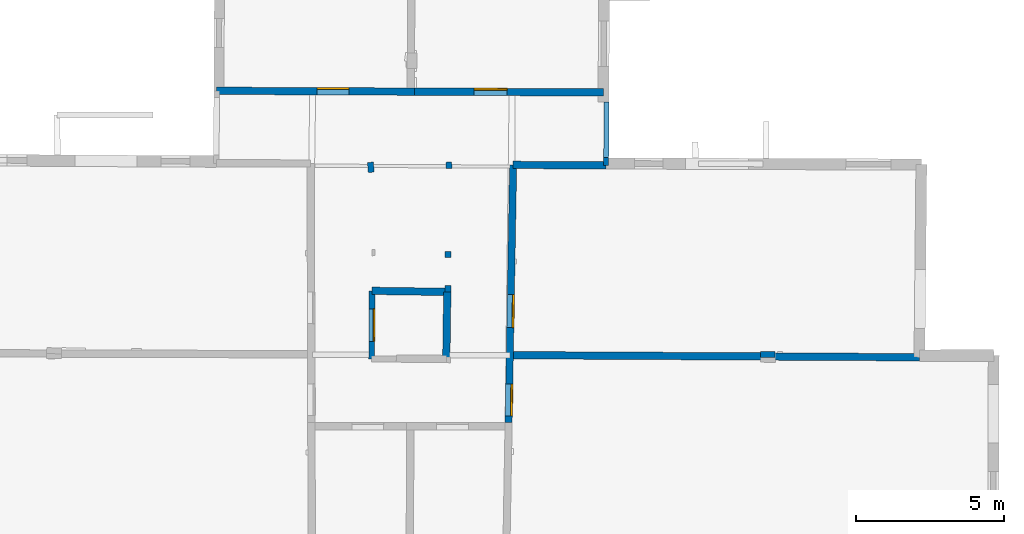
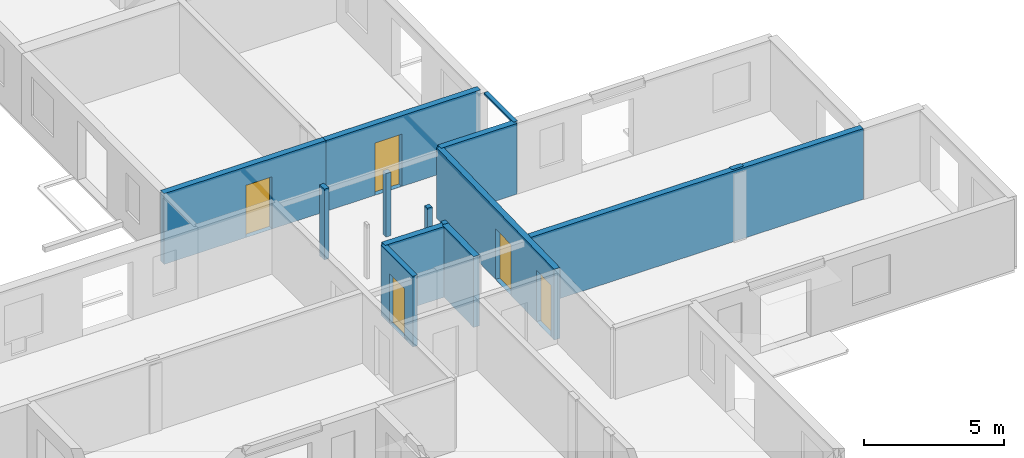
# One storey, part 6 of 17: 14 walls, 5 doors, 6 openings.
"""IFC2X3 building model written with IfcOpenShell, lengths in metres."""

from ifc_helpers import new_model, entity, si_unit, converted_unit, derived_unit, direction, frame, frame_2d, origin, origin_2d_with_axis, place, context, subcontext, project, spatial, polyline, rectangle, outline, extrude, clip, halfspace, source, transform, mapped, material, layer, layer_set, layer_usage, type_object, type_shapes, element, fill, save


model = new_model("IFC2X3")

# Units and contexts
model_context = context("Model", 3, precision=1e-05, world=origin(), true_north=direction((0.0, 1.0)))
body_context = subcontext(model_context, "Body", "Model", "MODEL_VIEW")
ifc_project = project(units=[si_unit("LENGTHUNIT", "METRE"), si_unit("AREAUNIT", "SQUARE_METRE"), si_unit("VOLUMEUNIT", "CUBIC_METRE"), converted_unit("PLANEANGLEUNIT", "DEGREE", entity("IfcRatioMeasure", 0.0174532925199433), si_unit("PLANEANGLEUNIT", "RADIAN"), dimensions=[0, 0, 0, 0, 0, 0, 0]), si_unit("MASSUNIT", "GRAM", prefix="KILO"), derived_unit("MASSDENSITYUNIT", [(si_unit("MASSUNIT", "GRAM", prefix="KILO"), 1), (si_unit("LENGTHUNIT", "METRE"), -3)]), derived_unit("MOMENTOFINERTIAUNIT", [(si_unit("LENGTHUNIT", "METRE"), 4)]), si_unit("TIMEUNIT", "SECOND"), si_unit("FREQUENCYUNIT", "HERTZ"), si_unit("THERMODYNAMICTEMPERATUREUNIT", "DEGREE_CELSIUS"), derived_unit("THERMALTRANSMITTANCEUNIT", [(si_unit("MASSUNIT", "GRAM", prefix="KILO"), 1), (si_unit("THERMODYNAMICTEMPERATUREUNIT", "KELVIN"), -1), (si_unit("TIMEUNIT", "SECOND"), -3)]), derived_unit("VOLUMETRICFLOWRATEUNIT", [(si_unit("LENGTHUNIT", "METRE"), 3), (si_unit("TIMEUNIT", "SECOND"), -1)]), si_unit("ELECTRICCURRENTUNIT", "AMPERE"), si_unit("ELECTRICVOLTAGEUNIT", "VOLT"), si_unit("POWERUNIT", "WATT"), si_unit("FORCEUNIT", "NEWTON", prefix="KILO"), si_unit("ILLUMINANCEUNIT", "LUX"), si_unit("LUMINOUSFLUXUNIT", "LUMEN"), si_unit("LUMINOUSINTENSITYUNIT", "CANDELA"), derived_unit("USERDEFINED", [(si_unit("MASSUNIT", "GRAM", prefix="KILO"), -1), (si_unit("LENGTHUNIT", "METRE"), -2), (si_unit("TIMEUNIT", "SECOND"), 3), (si_unit("LUMINOUSFLUXUNIT", "LUMEN"), 1)]), derived_unit("LINEARVELOCITYUNIT", [(si_unit("LENGTHUNIT", "METRE"), 1), (si_unit("TIMEUNIT", "SECOND"), -1)]), si_unit("PRESSUREUNIT", "PASCAL"), derived_unit("USERDEFINED", [(si_unit("LENGTHUNIT", "METRE"), -2), (si_unit("MASSUNIT", "GRAM", prefix="KILO"), 1), (si_unit("TIMEUNIT", "SECOND"), -2)]), derived_unit("LINEARFORCEUNIT", [(si_unit("MASSUNIT", "GRAM", prefix="KILO"), 1), (si_unit("LENGTHUNIT", "METRE"), 1), (si_unit("TIMEUNIT", "SECOND"), -2), (si_unit("LENGTHUNIT", "METRE"), -1)]), derived_unit("PLANARFORCEUNIT", [(si_unit("MASSUNIT", "GRAM", prefix="KILO"), 1), (si_unit("LENGTHUNIT", "METRE"), 1), (si_unit("TIMEUNIT", "SECOND"), -2), (si_unit("LENGTHUNIT", "METRE"), -2)])], contexts=[model_context])

# Site, building, storey
placement = place(None, origin())
site = spatial("IfcSite", under=ifc_project, at=placement, CompositionType="ELEMENT")
building = spatial("IfcBuilding", under=site, at=placement, CompositionType="ELEMENT")
storey_placement = place(placement, frame((0.0, 0.0, 12.0782108306885)))
storey = spatial("IfcBuildingStorey", under=building, at=storey_placement, Name="Level 5", CompositionType="ELEMENT", Elevation=12.0782108306885)

# Walls
ifc_material_1 = material(Name="Default wall")
ifc_layer_1 = layer(ifc_material_1, 0.25)
ifc_layer_set_1 = layer_set([ifc_layer_1], Name="wall_thickness_0.2500")
ifc_layer_usage_1 = layer_usage(ifc_layer_set_1, "AXIS2", "POSITIVE", -0.125)
wall_type_1 = type_object("IfcWallType", Name="wall_thickness_0.2500", PredefinedType="STANDARD", material=ifc_layer_set_1)
wall_1_placement = place(storey_placement, frame((7.44140047618452, 21.5416471038313, 0.0), z_axis=(0.0, 0.0, 1.0), x_axis=(-0.0141130984872263, -0.999900405265989, 0.0)))
element("IfcWallStandardCase", 1, at=wall_1_placement, inside=storey, type_object=wall_type_1, material=ifc_layer_usage_1, Name="Wall:255", ObjectType="Wall", context=body_context, shape_type="Clipping", body=[
    clip(clip(extrude(outline(polyline([(2.28926188819934, -0.125), (2.28926188819934, 0.125), (0.0, 0.125), (0.0, -0.125), (2.28926188819934, -0.125)])), origin(), (0.0, 0.0, 1.0), 3.09134044647217), halfspace(frame((2.06553112983233, 16.9692089835164, 9.08176747891542), z_axis=(-0.389130197139845, -0.00215358225991096, 0.921180249330909), x_axis=(0.00430704897289366, -0.999990590220069, -0.000518459702406835)), False)), halfspace(frame((-55.765283667153, 4.58856008528925, 6.35864093399329), z_axis=(-0.00360749198056489, 0.390483459134606, 0.920602875372374), x_axis=(0.679840338462808, -0.674176343923491, 0.288623234499112)), False)),
])
wall_2_placement = place(storey_placement, frame((9.66529580655071, 25.8279105453646, 0.0), z_axis=(0.0, 0.0, 1.0), x_axis=(0.999991390371742, -0.0041496002686868, 0.0)))
element("IfcWallStandardCase", 2, at=wall_2_placement, inside=storey, type_object=wall_type_1, material=ifc_layer_usage_1, Name="Wall:282", ObjectType="Wall", context=body_context, shape_type="Clipping", body=[
    clip(clip(extrude(outline(polyline([(3.13938459576782, -0.125), (3.13938459576782, 0.125), (0.0, 0.125), (0.0, -0.125), (3.13938459576782, -0.125)])), origin(), (0.0, 0.0, 1.0), 3.09134044647217), halfspace(frame((14.7416962136705, -6.52996104694493, 9.08176747891542), z_axis=(0.00172373620587876, 0.389132338640901, 0.921180249330909), x_axis=(-0.999983865431084, 0.00565686105937413, -0.000518459702406835)), False)), halfspace(frame((2.93787598171602, 51.4213412262231, 6.35864093399329), z_axis=(0.390500019911143, -0.000283382275309442, 0.920602875372374), x_axis=(-0.680916664311075, -0.673089239826897, 0.288623234499112)), False)),
])
wall_3_placement = place(storey_placement, frame((4.89979152095251, 21.5786000741626, 0.0), z_axis=(0.0, 0.0, 1.0), x_axis=(0.999894344321697, -0.0145361684595151, 0.0)))
element("IfcWallStandardCase", 3, at=wall_3_placement, inside=storey, type_object=wall_type_1, material=ifc_layer_usage_1, Name="Wall:289", ObjectType="Wall", context=body_context, shape_type="Clipping", body=[
    clip(clip(extrude(outline(polyline([(2.54187737420294, -0.125), (2.54187737420294, 0.125), (0.0, 0.125), (0.0, -0.125), (2.54187737420294, -0.125)])), origin(), (0.0, 0.0, 1.0), 3.09134044647217), halfspace(frame((19.5119589928247, -2.05835485575856, 9.08176747891542), z_axis=(-0.00231822825834028, 0.389129251098381, 0.921180249330909), x_axis=(-0.999988678338414, -0.00473015798140642, -0.000518459702406836)), False)), halfspace(frame((-6.95074935791861, 54.1698894244232, 5.79573318480268), z_axis=(-0.389877573655058, -0.00425334585105643, 0.920856876289642), x_axis=(0.920822647172364, 0.00783906332480271, 0.389902810378011)), False)),
])

# Wall, opening, door
wall_4_placement = place(storey_placement, frame((-0.341203083440317, 28.3289498440354, 0.0), z_axis=(0.0, 0.0, 1.0), x_axis=(0.999991697178327, -0.00407499379250348, 0.0)))
wall_4 = element("IfcWallStandardCase", 4, at=wall_4_placement, inside=storey, type_object=wall_type_1, material=ifc_layer_usage_1, Name="Wall:322", ObjectType="Wall", context=body_context, shape_type="Clipping", body=[
    clip(extrude(outline(polyline([(6.67924084701808, -0.125), (6.67924084701808, 0.125), (0.0, 0.125), (0.0, -0.125), (6.67924084701808, -0.125)])), origin(), (0.0, 0.0, 1.0), 3.09134044647217), halfspace(frame((-1.11521281073508, 47.5107035493444, 5.79573318480268), z_axis=(-0.389900734764027, -0.000174414893670282, 0.920856876289642), x_axis=(0.920854265394048, -0.00179453752182769, 0.389902810378011)), False)),
])
opening_1_placement = place(wall_4_placement, frame((3.3872048531384, -0.125, 0.00578975677490234)))
opening_1 = element("IfcOpeningElement", 5, at=opening_1_placement, cuts=wall_4, Name="Opening : 1075 x 2280 : 266", ObjectType="Opening", context=body_context, shape_type="SweptSolid", body=[
    extrude(rectangle(XDim=1.075, YDim=2.28, at=frame_2d((1.14, 0.5375), x_axis=(0.0, 1.0))), frame((0.0, 0.0, 0.0), z_axis=(0.0, 1.0, 0.0), x_axis=(0.0, 0.0, 1.0)), (0.0, 0.0, 1.0), 0.25),
])
ifc_material_2 = material(Name="Door Panel")
door_style_1 = type_object("IfcDoorStyle", Name="Door : 1075 x 2280mm", ConstructionType="NOTDEFINED", OperationType="SINGLE_SWING_RIGHT", ParameterTakesPrecedence=False, Sizeable=False, material=ifc_material_2)
shared_shape_1 = source(origin(), body_context, "Body", "SweptSolid", [
    extrude(rectangle(XDim=0.0625, YDim=1.075, at=origin_2d_with_axis()), frame((0.5375, 0.21875, 0.0), z_axis=(0.0, 0.0, 1.0), x_axis=(0.0, 1.0, 0.0)), (0.0, 0.0, 1.0), 2.28),
])
type_shapes(door_style_1, [shared_shape_1])
door_1_placement = place(opening_1_placement, origin())
door_1 = element("IfcDoor", 6, at=door_1_placement, inside=storey, type_object=door_style_1, Name="Door : 1075 x 2280mm : 50", ObjectType="Door : 1075 x 2280mm", OverallHeight=2.28, OverallWidth=1.075, context=body_context, shape_type="MappedRepresentation", body=[
    mapped(shared_shape_1, transform((0.0, 0.0, 0.0), scale=1.0)),
])
fill(opening_1, door_1)

wall_5_placement = place(storey_placement, frame((6.3379823070321, 28.3017319790451, 0.0), z_axis=(0.0, 0.0, 1.0), x_axis=(0.999991697084949, -0.00407501670713121, 0.0)))
wall_5 = element("IfcWallStandardCase", 7, at=wall_5_placement, inside=storey, type_object=wall_type_1, material=ifc_layer_usage_1, Name="Wall:323", ObjectType="Wall", context=body_context, shape_type="Clipping", body=[
    clip(extrude(outline(polyline([(6.37870934921096, -0.125), (6.37870934921096, 0.125), (0.0, 0.125), (0.0, -0.125), (6.37870934921096, -0.125)])), origin(), (0.0, 0.0, 1.0), 3.09134044647217), halfspace(frame((6.27907792952954, 48.9608799284421, 6.35864093399329), z_axis=(0.390499997689168, -0.000312507403043239, 0.920602875372374), x_axis=(-0.680966864234374, -0.673038452335433, 0.288623234499112)), False)),
])
opening_2_placement = place(wall_5_placement, frame((2.0109763124588, -0.125, 0.00578975677490234)))
opening_2 = element("IfcOpeningElement", 8, at=opening_2_placement, cuts=wall_5, Name="Opening : 1115 x 2280 : 267", ObjectType="Opening", context=body_context, shape_type="SweptSolid", body=[
    extrude(rectangle(XDim=1.115, YDim=2.28, at=frame_2d((1.14, 0.5575), x_axis=(0.0, 1.0))), frame((0.0, 0.0, 0.0), z_axis=(0.0, 1.0, 0.0), x_axis=(0.0, 0.0, 1.0)), (0.0, 0.0, 1.0), 0.25),
])
door_style_2 = type_object("IfcDoorStyle", Name="Door : 1115 x 2280mm", ConstructionType="NOTDEFINED", OperationType="SINGLE_SWING_RIGHT", ParameterTakesPrecedence=False, Sizeable=False, material=ifc_material_2)
shared_shape_2 = source(origin(), body_context, "Body", "SweptSolid", [
    extrude(rectangle(XDim=0.0625, YDim=1.115, at=origin_2d_with_axis()), frame((0.5575, 0.21875, 0.0), z_axis=(0.0, 0.0, 1.0), x_axis=(0.0, 1.0, 0.0)), (0.0, 0.0, 1.0), 2.28),
])
type_shapes(door_style_2, [shared_shape_2])
door_2_placement = place(opening_2_placement, origin())
door_2 = element("IfcDoor", 9, at=door_2_placement, inside=storey, type_object=door_style_2, Name="Door : 1115 x 2280mm : 51", ObjectType="Door : 1115 x 2280mm", OverallHeight=2.28, OverallWidth=1.115, context=body_context, shape_type="MappedRepresentation", body=[
    mapped(shared_shape_2, transform((0.0, 0.0, 0.0), scale=1.0)),
])
fill(opening_2, door_2)

# Wall
wall_6_placement = place(storey_placement, frame((9.61450464191011, 19.407159536809, 0.0), z_axis=(0.0, 0.0, 1.0), x_axis=(0.999986890430115, -0.00512044606555081, 0.0)))
element("IfcWallStandardCase", 10, at=wall_6_placement, inside=storey, type_object=wall_type_1, material=ifc_layer_usage_1, Name="Wall:357", ObjectType="Wall", context=body_context, shape_type="Clipping", body=[
    clip(extrude(outline(polyline([(13.763003531915, -0.125), (13.763003531915, 0.125), (0.0, 0.125), (0.0, -0.125), (13.763003531915, -0.125)])), origin(), (0.0, 0.0, 1.0), 3.09134044647217), halfspace(frame((14.7659423083296, -0.094718994949792, 9.08176747891542), z_axis=(0.00134594388447911, 0.38913382875009, 0.921180249330909), x_axis=(-0.999988886155912, 0.00468601794654678, -0.000518459702406836)), False)),
])

# Wall, opening, door
ifc_layer_2 = layer(ifc_material_1, 0.2)
ifc_layer_set_2 = layer_set([ifc_layer_2], Name="wall_thickness_0.2000")
ifc_layer_usage_2 = layer_usage(ifc_layer_set_2, "AXIS2", "POSITIVE", -0.1)
wall_type_2 = type_object("IfcWallType", Name="wall_thickness_0.2000", PredefinedType="STANDARD", material=ifc_layer_set_2)
wall_7_placement = place(storey_placement, frame((4.89979212972418, 21.5785997161123, 0.0), z_axis=(0.0, 0.0, 1.0), x_axis=(-0.00356916132915824, -0.999993630523418, 0.0)))
wall_7 = element("IfcWallStandardCase", 11, at=wall_7_placement, inside=storey, type_object=wall_type_2, material=ifc_layer_usage_2, Name="Wall:266", ObjectType="Wall", context=body_context, shape_type="Clipping", body=[
    clip(clip(extrude(outline(polyline([(2.29443294929788, -0.1), (2.29443294929788, 0.1), (0.0, 0.1), (0.0, -0.1), (2.29443294929788, -0.1)])), origin(), (0.0, 0.0, 1.0), 3.09134044647217), halfspace(frame((2.27222405000463, 19.4882103057675, 9.08176747891542), z_axis=(-0.389131272557736, 0.00194960515011499, 0.921180249330909), x_axis=(-0.00623729397913293, -0.999980413489862, -0.000518459702406836)), False)), halfspace(frame((-54.2428627602878, -6.35623495648199, 5.79573318480268), z_axis=(-2.2811012031869e-05, -0.389900773107391, 0.920856876289642), x_axis=(0.0022603386610801, 0.92085323984252, 0.389902810378011)), False)),
])
opening_3_placement = place(wall_7_placement, frame((0.61249935258112, -0.1, 0.00578975677490234)))
opening_3 = element("IfcOpeningElement", 12, at=opening_3_placement, cuts=wall_7, Name="Opening : 1095 x 2185 : 233", ObjectType="Opening", context=body_context, shape_type="SweptSolid", body=[
    extrude(rectangle(XDim=1.095, YDim=2.185, at=frame_2d((1.0925, 0.5475), x_axis=(0.0, 1.0))), frame((0.0, 0.0, 0.0), z_axis=(0.0, 1.0, 0.0), x_axis=(0.0, 0.0, 1.0)), (0.0, 0.0, 1.0), 0.2),
])
door_style_3 = type_object("IfcDoorStyle", Name="Door : 1095 x 2185mm", ConstructionType="NOTDEFINED", OperationType="SINGLE_SWING_RIGHT", ParameterTakesPrecedence=False, Sizeable=False, material=ifc_material_2)
shared_shape_3 = source(origin(), body_context, "Body", "SweptSolid", [
    extrude(rectangle(XDim=0.05, YDim=1.095, at=origin_2d_with_axis()), frame((0.5475, 0.175, 0.0), z_axis=(0.0, 0.0, 1.0), x_axis=(0.0, 1.0, 0.0)), (0.0, 0.0, 1.0), 2.185),
])
type_shapes(door_style_3, [shared_shape_3])
door_3_placement = place(opening_3_placement, origin())
door_3 = element("IfcDoor", 13, at=door_3_placement, inside=storey, type_object=door_style_3, Name="Door : 1095 x 2185mm : 40", ObjectType="Door : 1095 x 2185mm", OverallHeight=2.185, OverallWidth=1.095, context=body_context, shape_type="MappedRepresentation", body=[
    mapped(shared_shape_3, transform((0.0, 0.0, 0.0), scale=1.0)),
])
fill(opening_3, door_3)

# Walls
wall_8_placement = place(storey_placement, frame((18.0131439674887, 19.433039885868, 0.0), z_axis=(0.0, 0.0, 1.0), x_axis=(0.999992071495459, -0.00398207812852465, 0.0)))
element("IfcWallStandardCase", 14, at=wall_8_placement, inside=storey, type_object=wall_type_2, material=ifc_layer_usage_2, Name="Wall:305", ObjectType="Wall", context=body_context, shape_type="Clipping", body=[
    clip(extrude(outline(polyline([(0.489999841386866, -0.1), (0.489999841386866, 0.1), (0.0, 0.1), (0.0, -0.1), (0.489999841386866, -0.1)])), origin(), (0.0, 0.0, 1.0), 3.09134044647217), halfspace(frame((6.36735523515238, -0.170852362065584, 9.08176747891542), z_axis=(0.00178892500245993, 0.389132044414207, 0.921180249330909), x_axis=(-0.999982903741944, 0.0058243818013268, -0.000518459702406835)), False)),
])
wall_9_placement = place(storey_placement, frame((7.46861126663325, 21.761036742165, 0.0), z_axis=(0.0, 0.0, 1.0), x_axis=(-0.0142359733578383, -0.999898663396724, 0.0)))
element("IfcWallStandardCase", 15, at=wall_9_placement, inside=storey, type_object=wall_type_2, material=ifc_layer_usage_2, Name="Wall:352", ObjectType="Wall", context=body_context, shape_type="Clipping", body=[
    clip(clip(extrude(outline(polyline([(0.219762183893674, -0.1), (0.219762183893674, 0.1), (0.0, 0.1), (0.0, -0.1), (0.219762183893674, -0.1)])), origin(), (0.0, 0.0, 1.0), 3.09134044647217), halfspace(frame((2.28320059360581, 16.945377874805, 9.08176747891542), z_axis=(-0.389129929553936, -0.00220140137027481, 0.921180249330909), x_axis=(0.0044299350001254, -0.999990053388248, -0.000518459702406836)), False)), halfspace(frame((-55.5460923432437, 4.5576224022248, 6.35864093399329), z_axis=(-0.00365547737854998, 0.390483012871561, 0.920602875372374), x_axis=(0.679923180983644, -0.67409279514645, 0.288623234499112)), False)),
])
wall_10_placement = place(storey_placement, frame((4.84923252095898, 25.9168811524199, 0.0), z_axis=(0.0, 0.0, 1.0), x_axis=(0.0773852229796597, -0.997001267433692, 0.0)))
element("IfcWallStandardCase", 16, at=wall_10_placement, inside=storey, type_object=wall_type_2, material=ifc_layer_usage_2, Name="Wall:356", ObjectType="Wall", context=body_context, shape_type="Clipping", body=[
    clip(clip(extrude(outline(polyline([(0.339999288006803, -0.1), (0.339999288006803, 0.1), (0.0, 0.1), (0.0, -0.1), (0.339999288006803, -0.1)])), origin(), (0.0, 0.0, 1.0), 3.09134044647217), halfspace(frame((8.17139077552214, 18.9550320252348, 9.08176747891542), z_axis=(-0.387696615359257, 0.0334407338678561, 0.921180249330909), x_axis=(-0.087158430701197, -0.996194328008969, -0.000518459702406836)), False)), halfspace(frame((-50.2501858280312, -2.23009896901316, 5.79573318480268), z_axis=(-0.0315825479151768, -0.388619551820632, 0.920856876289642), x_axis=(0.0767897191724997, 0.917648700477878, 0.389902810378011)), False)),
])
wall_11_placement = place(storey_placement, frame((7.498337734999, 25.7056823771915, 0.0), z_axis=(0.0, 0.0, 1.0), x_axis=(-0.0373305892936721, 0.99930297062652, 0.0)))
element("IfcWallStandardCase", 17, at=wall_11_placement, inside=storey, type_object=wall_type_2, material=ifc_layer_usage_2, Name="Wall:359", ObjectType="Wall", context=body_context, shape_type="Clipping", body=[
    clip(clip(extrude(outline(polyline([(0.215001241575244, -0.1), (0.215001241575244, 0.1), (0.0, 0.1), (0.0, -0.1), (0.215001241575244, -0.1)])), origin(), (0.0, 0.0, 1.0), 2.77578926086426), halfspace(frame((-7.09453358095817, -16.628177845628, 9.08176747891542), z_axis=(0.388725979324053, -0.0178622854416868, 0.921180249330909), x_axis=(0.0471282996574856, 0.998888709802514, -0.000518459702406835)), False)), halfspace(frame((51.2964860428785, -7.23816003344477, 6.35864093399329), z_axis=(-0.0164798982762256, -0.390152225174896, 0.920602875372374), x_axis=(-0.644267655611648, 0.70824841435752, 0.288623234499112)), False)),
])
wall_12_placement = place(storey_placement, frame((7.46792618623953, 22.6989965194246, 0.0), z_axis=(0.0, 0.0, 1.0), x_axis=(-0.00580812146413309, 0.999983132720276, 0.0)))
element("IfcWallStandardCase", 18, at=wall_12_placement, inside=storey, type_object=wall_type_2, material=ifc_layer_usage_2, Name="Wall:364", ObjectType="Wall", context=body_context, shape_type="Clipping", body=[
    clip(clip(extrude(outline(polyline([(0.204999566793825, -0.1), (0.204999566793825, 0.1), (0.0, 0.1), (0.0, -0.1), (0.204999566793825, -0.1)])), origin(), (0.0, 0.0, 1.0), 3.09134044647217), halfspace(frame((-3.56033058336078, -16.8914482656447, 9.08176747891542), z_axis=(0.3890958819027, -0.00559847559646864, 0.921180249330909), x_axis=(0.0156140216756689, 0.99987795931636, -0.000518459702406835)), False)), halfspace(frame((54.5056363125481, -5.66526923323972, 6.35864093399329), z_axis=(-0.00417181190136448, -0.390477837836639, 0.920602875372374), x_axis=(-0.666275572353215, 0.687585260307888, 0.288623234499112)), False)),
])

# Wall, openings, doors
ifc_layer_3 = layer(ifc_material_1, 0.239999994635582)
ifc_layer_set_3 = layer_set([ifc_layer_3], Name="wall_thickness_0.2400")
ifc_layer_usage_3 = layer_usage(ifc_layer_set_3, "AXIS2", "POSITIVE", -0.119999997317791)
wall_type_3 = type_object("IfcWallType", Name="wall_thickness_0.2400", PredefinedType="STANDARD", material=ifc_layer_set_3)
wall_13_placement = place(storey_placement, frame((9.66529603965093, 25.8279074952935, 0.0), z_axis=(0.0, 0.0, 1.0), x_axis=(-0.0176752883590559, -0.99984377988835, 0.0)))
wall_13 = element("IfcWallStandardCase", 19, at=wall_13_placement, inside=storey, type_object=wall_type_3, material=ifc_layer_usage_3, Name="Wall:370", ObjectType="Wall", context=body_context, shape_type="Clipping", body=[
    clip(clip(extrude(outline(polyline([(8.69655854377734, -0.119999997317791), (8.69655854377734, 0.119999997317791), (0.0, 0.119999997317791), (0.0, -0.119999997317791), (8.69655854377734, -0.119999997317791)])), origin(), (0.0, 0.0, 1.0), 3.09134044647217), halfspace(frame((6.32996172308343, 14.8286727676038, 9.08176747891542), z_axis=(-0.389120055215249, -0.00353989716322151, 0.921180249330909), x_axis=(0.00786962237189669, -0.999968899638014, -0.000518459702406836)), False)), halfspace(frame((-51.4563783440185, 2.24207239762138, 6.35864093399329), z_axis=(-0.00499861883461119, 0.390468128873361, 0.920602875372374), x_axis=(0.682237867796445, -0.671750042986103, 0.288623234499112)), False)),
])
opening_4_placement = place(wall_13_placement, frame((4.37408305446356, -0.119999997317791, 0.00578975677490234)))
opening_4 = element("IfcOpeningElement", 20, at=opening_4_placement, cuts=wall_13, Name="Opening : 1120 x 2215 : 302", ObjectType="Opening", context=body_context, shape_type="SweptSolid", body=[
    extrude(rectangle(XDim=1.12, YDim=2.215, at=frame_2d((1.1075, 0.56), x_axis=(0.0, 1.0))), frame((0.0, 0.0, 0.0), z_axis=(0.0, 1.0, 0.0), x_axis=(0.0, 0.0, 1.0)), (0.0, 0.0, 1.0), 0.239999994635582),
])
opening_5_placement = place(wall_13_placement, frame((7.39403649989452, -0.119999997317791, 0.00578975677490234)))
opening_5 = element("IfcOpeningElement", 21, at=opening_5_placement, cuts=wall_13, Name="Opening : 1075 x 2250 : 303", ObjectType="Opening", context=body_context, shape_type="SweptSolid", body=[
    extrude(rectangle(XDim=1.075, YDim=2.25, at=frame_2d((1.125, 0.5375), x_axis=(0.0, 1.0))), frame((0.0, 0.0, 0.0), z_axis=(0.0, 1.0, 0.0), x_axis=(0.0, 0.0, 1.0)), (0.0, 0.0, 1.0), 0.239999994635582),
])
door_style_4 = type_object("IfcDoorStyle", Name="Door : 1120 x 2215mm", ConstructionType="NOTDEFINED", OperationType="SINGLE_SWING_RIGHT", ParameterTakesPrecedence=False, Sizeable=False, material=ifc_material_2)
shared_shape_4 = source(origin(), body_context, "Body", "SweptSolid", [
    extrude(rectangle(XDim=0.0599999986588955, YDim=1.12, at=origin_2d_with_axis()), frame((0.56, 0.209999995306134, 0.0), z_axis=(0.0, 0.0, 1.0), x_axis=(0.0, 1.0, 0.0)), (0.0, 0.0, 1.0), 2.215),
])
type_shapes(door_style_4, [shared_shape_4])
door_4_placement = place(opening_4_placement, origin())
door_4 = element("IfcDoor", 22, at=door_4_placement, inside=storey, type_object=door_style_4, Name="Door : 1120 x 2215mm : 55", ObjectType="Door : 1120 x 2215mm", OverallHeight=2.215, OverallWidth=1.12, context=body_context, shape_type="MappedRepresentation", body=[
    mapped(shared_shape_4, transform((0.0, 0.0, 0.0), scale=1.0)),
])
fill(opening_4, door_4)
door_style_5 = type_object("IfcDoorStyle", Name="Door : 1075 x 2250mm", ConstructionType="NOTDEFINED", OperationType="SINGLE_SWING_RIGHT", ParameterTakesPrecedence=False, Sizeable=False, material=ifc_material_2)
shared_shape_5 = source(origin(), body_context, "Body", "SweptSolid", [
    extrude(rectangle(XDim=0.0599999986588955, YDim=1.075, at=origin_2d_with_axis()), frame((0.5375, 0.209999995306134, 0.0), z_axis=(0.0, 0.0, 1.0), x_axis=(0.0, 1.0, 0.0)), (0.0, 0.0, 1.0), 2.25),
])
type_shapes(door_style_5, [shared_shape_5])
door_5_placement = place(opening_5_placement, origin())
door_5 = element("IfcDoor", 23, at=door_5_placement, inside=storey, type_object=door_style_5, Name="Door : 1075 x 2250mm : 56", ObjectType="Door : 1075 x 2250mm", OverallHeight=2.25, OverallWidth=1.075, context=body_context, shape_type="MappedRepresentation", body=[
    mapped(shared_shape_5, transform((0.0, 0.0, 0.0), scale=1.0)),
])
fill(opening_5, door_5)

# Wall, opening
ifc_layer_4 = layer(ifc_material_1, 0.170000001788139)
ifc_layer_set_4 = layer_set([ifc_layer_4], Name="wall_thickness_0.1700")
ifc_layer_usage_4 = layer_usage(ifc_layer_set_4, "AXIS2", "POSITIVE", -0.0850000008940697)
wall_type_4 = type_object("IfcWallType", Name="wall_thickness_0.1700", PredefinedType="STANDARD", material=ifc_layer_set_4)
wall_14_placement = place(storey_placement, frame((12.8150340047228, 27.9459821396896, 0.0), z_axis=(0.0, 0.0, 1.0), x_axis=(-0.00487147269600703, -0.999988134306489, 0.0)))
wall_14 = element("IfcWallStandardCase", 24, at=wall_14_placement, inside=storey, type_object=wall_type_4, material=ifc_layer_usage_4, Name="Wall:321", ObjectType="Wall", context=body_context, shape_type="Clipping", body=[
    clip(clip(extrude(outline(polyline([(2.13112117346115, -0.0850000008940697), (2.13112117346115, 0.0850000008940697), (0.0, 0.0850000008940697), (0.0, -0.0850000008940697), (2.13112117346115, -0.0850000008940697)])), origin(), (0.0, 0.0, 1.0), 3.09134044647217), halfspace(frame((8.65270793950955, 11.6070235227168, 9.08176747891542), z_axis=(-0.389133481580662, 0.00144282901167429, 0.921180249330909), x_axis=(-0.00493499150903141, -0.999987688453384, -0.000518459702406836)), False)), halfspace(frame((-49.2900582956584, -0.238627503760268, 6.35864093399329), z_axis=(1.48815501930014e-06, 0.39050012273225, 0.920602875372374), x_axis=(0.673580604383446, -0.680430597420267, 0.288623234499112)), False)),
])
opening_6_placement = place(wall_14_placement, frame((-0.0912334070689667, -0.0850000008940697, 0.00578975677490234)))
element("IfcOpeningElement", 25, at=opening_6_placement, cuts=wall_14, Name="Opening : 1960 x 2995 : 265", ObjectType="Opening", context=body_context, shape_type="SweptSolid", body=[
    extrude(rectangle(XDim=1.96, YDim=2.995, at=frame_2d((1.4975, 0.98), x_axis=(0.0, 1.0))), frame((0.0, 0.0, 0.0), z_axis=(0.0, 1.0, 0.0), x_axis=(0.0, 0.0, 1.0)), (0.0, 0.0, 1.0), 0.170000001788139),
])

save(model, "model.ifc")
